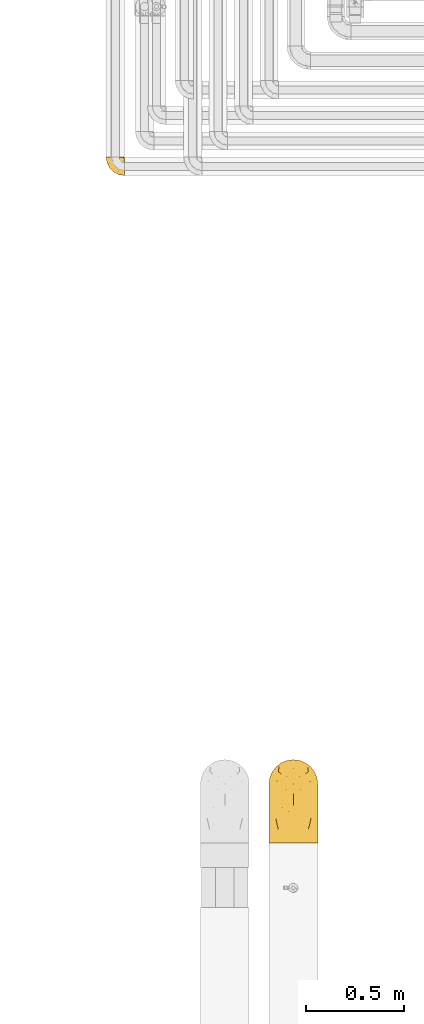
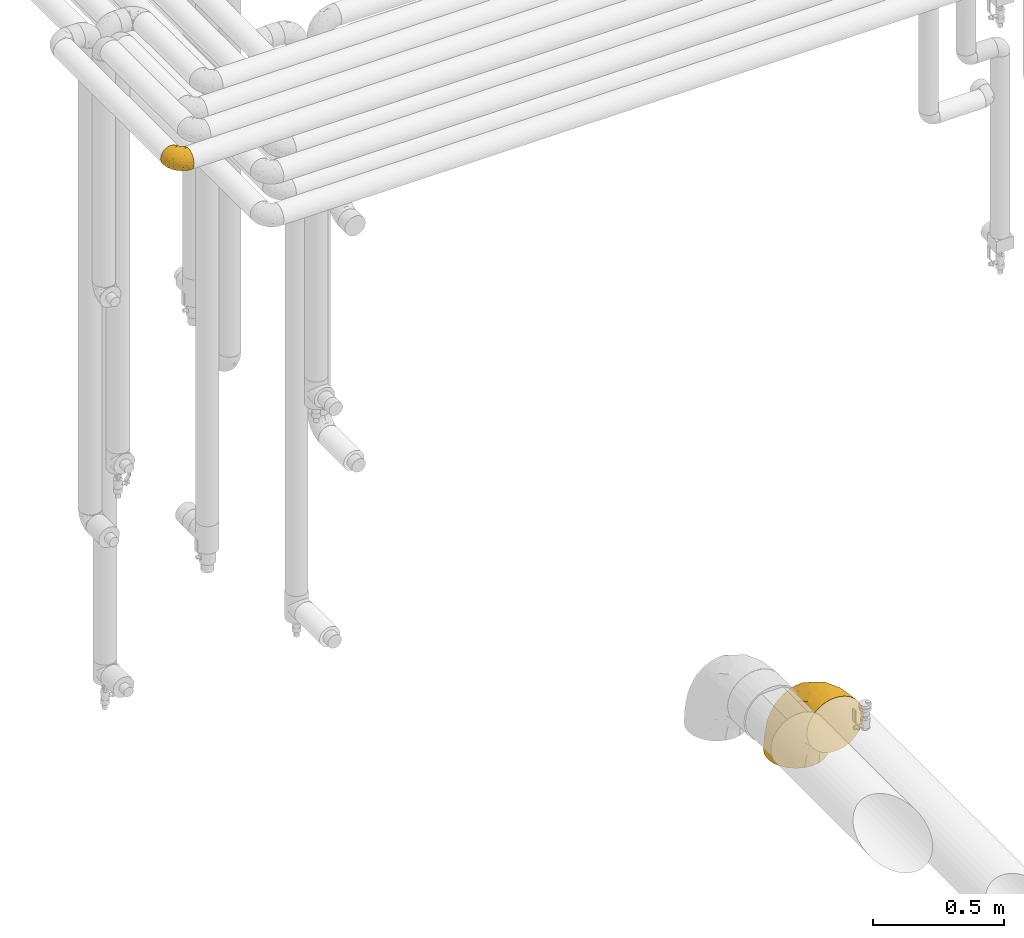
# One storey, part 142 of 827: 2 coverings.
"""IFC2X3 building model written with IfcOpenShell, lengths in millimetres."""

import ifcopenshell
import ifcopenshell.guid

model = None  # the IFC model being written
_history = None  # IfcOwnerHistory: only IFC2X3 demands one
_inside = {}  # id of a spatial element -> (the spatial element, [elements in it])
_under = {}  # id of a project, library or spatial element -> (it, [spatial elements below it])
_declared = {}  # id of a project -> (the project, [libraries it declares])
_typed = {}  # id of a type object -> (the type object, [elements of that type])
_made_of = {}  # id of a material, layer set ... -> (it, [elements and type objects made of it])


def new_model(schema):
    """Start an empty IFC model of exactly this schema.

    Asked for "IFC4X3", IfcOpenShell would pick the latest addendum, in which some entities
    have other attributes; the version numbers below select the first issue.
    IFC2X3 requires an IfcOwnerHistory on every rooted entity: one is made here for all.
    """
    global model, _history
    if schema == "IFC4X3":
        model = ifcopenshell.file(schema_version=(4, 3, 0, 0))
    else:
        model = ifcopenshell.file(schema=schema)
    _inside.clear()
    _under.clear()
    _declared.clear()
    _typed.clear()
    _made_of.clear()
    _history = None
    if model.schema == "IFC2X3":
        org = make("IfcOrganization", Name="unknown")
        user = make(
            "IfcPersonAndOrganization",
            ThePerson=make("IfcPerson", FamilyName="unknown"),
            TheOrganization=org,
        )
        app = make(
            "IfcApplication",
            ApplicationDeveloper=org,
            Version="unknown",
            ApplicationFullName="unknown",
            ApplicationIdentifier="unknown",
        )
        _history = make(
            "IfcOwnerHistory",
            OwningUser=user,
            OwningApplication=app,
            ChangeAction="ADDED",
            CreationDate=0,
        )
    return model


def make(cls, **values):
    """One entity of the class cls with the attributes given. An attribute that is None is left unset."""
    return model.create_entity(
        cls, **{name: value for name, value in values.items() if value is not None}
    )


def entity(cls, *values):
    """Any entity or typed value of the class cls, its attributes in the order of the schema. None: left unset."""
    e = model.create_entity(cls)
    for i, value in enumerate(values):
        if value is not None:
            e[i] = value
    return e


def rooted(cls, **values):
    """An entity with a GlobalId (a new one), such as an element, a storey or a relation."""
    return make(cls, GlobalId=ifcopenshell.guid.new(), OwnerHistory=_history, **values)


def si_unit(unit_type, name, prefix=None):
    """IfcSIUnit, for example si_unit("LENGTHUNIT", "METRE", prefix="MILLI")."""
    return make("IfcSIUnit", UnitType=unit_type, Prefix=prefix, Name=name)


def converted_unit(unit_type, name, factor, base, dimensions=None, offset=None):
    """IfcConversionBasedUnit, such as the inch: factor (a typed value) times the base unit."""
    return make(
        "IfcConversionBasedUnit"
        if offset is None
        else "IfcConversionBasedUnitWithOffset",
        ConversionOffset=offset,
        Dimensions=None
        if dimensions is None
        else entity("IfcDimensionalExponents", *dimensions),
        UnitType=unit_type,
        Name=name,
        ConversionFactor=make(
            "IfcMeasureWithUnit", ValueComponent=factor, UnitComponent=base
        ),
    )


def derived_unit(unit_type, elements):
    """IfcDerivedUnit: a product of units, each with its exponent."""
    return make(
        "IfcDerivedUnit",
        Elements=[
            make("IfcDerivedUnitElement", Unit=unit, Exponent=power)
            for unit, power in elements
        ],
        UnitType=unit_type,
    )


def assignment(units):
    """IfcUnitAssignment: the units of a project."""
    return None if units is None else make("IfcUnitAssignment", Units=units)


def point(xyz):
    """IfcCartesianPoint."""
    return None if xyz is None else make("IfcCartesianPoint", Coordinates=xyz)


def direction(xyz):
    """IfcDirection."""
    return None if xyz is None else make("IfcDirection", DirectionRatios=xyz)


def frame(location, z_axis=None, x_axis=None):
    """IfcAxis2Placement3D, a coordinate frame: its origin and axes. An axis left out is left unset."""
    return make(
        "IfcAxis2Placement3D",
        Location=point(location),
        Axis=direction(z_axis),
        RefDirection=direction(x_axis),
    )


def origin():
    """The frame at (0, 0, 0) with its axes left unset."""
    return frame((0.0, 0.0, 0.0))


def place(relative_to, where):
    """IfcLocalPlacement: puts the frame where relative to a parent placement (None: the world)."""
    return make(
        "IfcLocalPlacement", PlacementRelTo=relative_to, RelativePlacement=where
    )


def context(
    kind, dimensions, precision=None, world=None, true_north=None, identifier=None
):
    """IfcGeometricRepresentationContext, for example the 3D "Model" context."""
    return make(
        "IfcGeometricRepresentationContext",
        ContextIdentifier=identifier,
        ContextType=kind,
        CoordinateSpaceDimension=dimensions,
        Precision=precision,
        WorldCoordinateSystem=world,
        TrueNorth=true_north,
    )


def subcontext(parent, identifier, kind, view, scale=None):
    """IfcGeometricRepresentationSubContext, for example "Body" below "Model"."""
    return make(
        "IfcGeometricRepresentationSubContext",
        ContextIdentifier=identifier,
        ContextType=kind,
        ParentContext=parent,
        TargetScale=scale,
        TargetView=view,
    )


def project(units=None, contexts=None):
    """IfcProject with its units and contexts."""
    return rooted(
        "IfcProject",
        Name="project",
        RepresentationContexts=contexts,
        UnitsInContext=assignment(units),
    )


def spatial(cls, under=None, at=None, **own):
    """A site, building, storey or space (cls), placed at a placement, below another one or the project."""
    s = rooted(cls, ObjectPlacement=at, **own)
    if under is not None:
        _under.setdefault(under.id(), (under, []))[1].append(s)
    return s


def faces_of(points, faces, orient=None, outer=None):
    """IfcFace entities. A face is a list of loops; a loop is a list of indices into points, from 0.

    orient and outer hold one flag for each loop. By default every Orientation is true, the
    first loop of a face is its IfcFaceOuterBound and the others are IfcFaceBound.
    """
    made = []
    for i, loops in enumerate(faces):
        bounds = []
        for j, loop in enumerate(loops):
            is_outer = j == 0 if outer is None else outer[i][j]
            bounds.append(
                make(
                    "IfcFaceOuterBound" if is_outer else "IfcFaceBound",
                    Bound=make("IfcPolyLoop", Polygon=[points[k] for k in loop]),
                    Orientation=True if orient is None else orient[i][j],
                )
            )
        made.append(make("IfcFace", Bounds=bounds))
    return made


def faceted_brep(points, faces, orient=None, outer=None, voids=None):
    """IfcFacetedBrep: a solid bounded by flat faces; with voids (closed shells), ...WithVoids."""
    shared = [point(p) for p in points]
    hull = make("IfcClosedShell", CfsFaces=faces_of(shared, faces, orient, outer))
    if voids is None:
        return make("IfcFacetedBrep", Outer=hull)
    return make(
        "IfcFacetedBrepWithVoids",
        Outer=hull,
        Voids=[
            make(cls, CfsFaces=faces_of(shared, fs, o, b)) for cls, fs, o, b in voids
        ],
    )


def shape(context_of_items, identifier, shape_type, items):
    """IfcShapeRepresentation: the items that make up one representation, for example the "Body"."""
    return make(
        "IfcShapeRepresentation",
        ContextOfItems=context_of_items,
        RepresentationIdentifier=identifier,
        RepresentationType=shape_type,
        Items=items,
    )


def made_of(thing, what):
    """Note that an element or type object is made of a material, layer set ...; save() writes the relation."""
    if what is not None:
        _made_of.setdefault(what.id(), (what, []))[1].append(thing)
    return thing


def element(
    cls,
    number,
    at=None,
    inside=None,
    cuts=None,
    type_object=None,
    material=None,
    context=None,
    identifier="Body",
    shape_type=None,
    held_by="IfcProductDefinitionShape",
    body=None,
    shapes=None,
    **own,
):
    """One element of the class cls, such as IfcWall. Its Tag is "e" and its number.

    at: its placement. inside: the storey or other place that contains it. cuts: it is an
    opening in that element (IfcRelVoidsElement). A single representation is given by context,
    identifier, shape_type and body (its items); several are given by shapes. held_by: the class
    of the entity that holds the representations. save() writes the other relations.
    """
    e = rooted(cls, Tag="e%d" % number, ObjectPlacement=at, **own)
    if body is not None:
        shapes = [shape(context, identifier, shape_type, body)]
    if shapes is not None:
        e.Representation = make(held_by, Representations=shapes)
    if inside is not None:
        _inside.setdefault(inside.id(), (inside, []))[1].append(e)
    if cuts is not None:
        rooted(
            "IfcRelVoidsElement", RelatingBuildingElement=cuts, RelatedOpeningElement=e
        )
    if type_object is not None:
        _typed.setdefault(type_object.id(), (type_object, []))[1].append(e)
    return made_of(e, material)


def aggregate(whole, parts):
    """IfcRelAggregates: a whole, such as a stair, and the parts it consists of."""
    return rooted("IfcRelAggregates", RelatingObject=whole, RelatedObjects=parts)


def save(model, path):
    """Write the relations noted so far, then the file.

    IfcRelAggregates (storeys below a building ...), IfcRelContainedInSpatialStructure (elements
    in a storey), IfcRelDefinesByType, IfcRelAssociatesMaterial and IfcRelDeclares: one each for
    every whole, place, type object, material and project.
    """
    for whole, parts in _under.values():
        aggregate(whole, parts)
    for where, things in _inside.values():
        rooted(
            "IfcRelContainedInSpatialStructure",
            RelatedElements=things,
            RelatingStructure=where,
        )
    for kind, things in _typed.values():
        rooted("IfcRelDefinesByType", RelatedObjects=things, RelatingType=kind)
    for what, things in _made_of.values():
        rooted("IfcRelAssociatesMaterial", RelatedObjects=things, RelatingMaterial=what)
    for by, libraries in _declared.values():
        rooted("IfcRelDeclares", RelatingContext=by, RelatedDefinitions=libraries)
    model.write(path)


model = new_model("IFC2X3")

# Units and contexts
model_context = context("Model", 3, precision=0.01, world=origin(), true_north=direction((6.12303176911189e-17, 1.0)))
body_context = subcontext(model_context, "Body", "Model", "MODEL_VIEW")
ifc_project = project(units=[si_unit("LENGTHUNIT", "METRE", prefix="MILLI"), si_unit("AREAUNIT", "SQUARE_METRE"), si_unit("VOLUMEUNIT", "CUBIC_METRE"), converted_unit("PLANEANGLEUNIT", "DEGREE", entity("IfcRatioMeasure", 0.0174532925199433), si_unit("PLANEANGLEUNIT", "RADIAN"), dimensions=[0, 0, 0, 0, 0, 0, 0]), si_unit("MASSUNIT", "GRAM", prefix="KILO"), derived_unit("MASSDENSITYUNIT", [(si_unit("MASSUNIT", "GRAM", prefix="KILO"), 1), (si_unit("LENGTHUNIT", "METRE"), -3)]), derived_unit("MOMENTOFINERTIAUNIT", [(si_unit("LENGTHUNIT", "METRE"), 4)]), si_unit("TIMEUNIT", "SECOND"), si_unit("FREQUENCYUNIT", "HERTZ"), si_unit("THERMODYNAMICTEMPERATUREUNIT", "DEGREE_CELSIUS"), derived_unit("THERMALTRANSMITTANCEUNIT", [(si_unit("MASSUNIT", "GRAM", prefix="KILO"), 1), (si_unit("THERMODYNAMICTEMPERATUREUNIT", "KELVIN"), -1), (si_unit("TIMEUNIT", "SECOND"), -3)]), derived_unit("VOLUMETRICFLOWRATEUNIT", [(si_unit("LENGTHUNIT", "METRE"), 3), (si_unit("TIMEUNIT", "SECOND"), -1)]), derived_unit("MASSFLOWRATEUNIT", [(si_unit("MASSUNIT", "GRAM", prefix="KILO"), 1), (si_unit("TIMEUNIT", "SECOND"), -1)]), derived_unit("ROTATIONALFREQUENCYUNIT", [(si_unit("TIMEUNIT", "SECOND"), -1)]), si_unit("ELECTRICCURRENTUNIT", "AMPERE"), si_unit("ELECTRICVOLTAGEUNIT", "VOLT"), si_unit("POWERUNIT", "WATT"), si_unit("FORCEUNIT", "NEWTON", prefix="KILO"), si_unit("ILLUMINANCEUNIT", "LUX"), si_unit("LUMINOUSFLUXUNIT", "LUMEN"), si_unit("LUMINOUSINTENSITYUNIT", "CANDELA"), derived_unit("USERDEFINED", [(si_unit("MASSUNIT", "GRAM", prefix="KILO"), -1), (si_unit("LENGTHUNIT", "METRE"), -2), (si_unit("TIMEUNIT", "SECOND"), 3), (si_unit("LUMINOUSFLUXUNIT", "LUMEN"), 1)]), derived_unit("LINEARVELOCITYUNIT", [(si_unit("LENGTHUNIT", "METRE"), 1), (si_unit("TIMEUNIT", "SECOND"), -1)]), si_unit("PRESSUREUNIT", "PASCAL"), derived_unit("USERDEFINED", [(si_unit("LENGTHUNIT", "METRE"), -2), (si_unit("MASSUNIT", "GRAM", prefix="KILO"), 1), (si_unit("TIMEUNIT", "SECOND"), -2)]), derived_unit("LINEARFORCEUNIT", [(si_unit("MASSUNIT", "GRAM", prefix="KILO"), 1), (si_unit("LENGTHUNIT", "METRE"), 1), (si_unit("TIMEUNIT", "SECOND"), -2), (si_unit("LENGTHUNIT", "METRE"), -1)]), derived_unit("PLANARFORCEUNIT", [(si_unit("MASSUNIT", "GRAM", prefix="KILO"), 1), (si_unit("LENGTHUNIT", "METRE"), 1), (si_unit("TIMEUNIT", "SECOND"), -2), (si_unit("LENGTHUNIT", "METRE"), -2)])], contexts=[model_context])

# Site, building, storey
site_placement = place(None, origin())
site = spatial("IfcSite", under=ifc_project, at=site_placement, CompositionType="ELEMENT")
building_placement = place(site_placement, origin())
building = spatial("IfcBuilding", under=site, at=building_placement, CompositionType="ELEMENT")
storey_placement = place(building_placement, frame((0.0, 0.0, 28200.0)))
storey = spatial("IfcBuildingStorey", under=building, at=storey_placement, Name="08", CompositionType="ELEMENT", Elevation=28200.0)

# Coverings
covering_1_placement = place(storey_placement, frame((30473.73, 14052.21, 3352.2)))
element("IfcCovering", 1, at=covering_1_placement, inside=storey, Name=":ADSK_", ObjectType=":ADSK_", PredefinedType="INSULATION", context=body_context, shape_type="Brep", body=[
    faceted_brep([(95.8, 18.98, 83.91), (95.8, 11.67, 76.59), (95.8, 6.17, 67.83), (95.8, 2.75, 58.07), (95.8, 1.6, 47.8), (95.8, 2.75, 37.51), (95.8, 6.17, 27.74), (95.8, 11.68, 18.98), (95.8, 19.0, 11.67), (95.8, 27.76, 6.17), (95.8, 37.52, 2.75), (95.8, 47.8, 1.6), (95.8, 51.94, 2.06), (95.8, 55.01, 2.41), (95.8, 58.08, 2.75), (95.8, 62.96, 4.46), (95.8, 67.85, 6.17), (95.8, 72.23, 8.93), (95.8, 76.61, 11.68), (95.8, 80.26, 15.34), (95.8, 83.92, 19.0), (95.8, 89.42, 27.76), (95.8, 91.13, 32.64), (95.8, 92.84, 37.52), (95.8, 94.0, 47.8), (95.8, 92.84, 58.08), (95.8, 91.13, 62.96), (95.8, 89.42, 67.85), (95.8, 83.91, 76.61), (95.8, 80.25, 80.26), (95.8, 76.59, 83.92), (95.8, 72.21, 86.67), (95.8, 67.83, 89.42), (95.8, 62.95, 91.13), (95.8, 58.07, 92.84), (95.8, 55.0, 93.18), (95.8, 51.94, 93.53), (95.8, 47.8, 94.0), (95.8, 37.51, 92.84), (95.8, 27.74, 89.42), (94.0, 95.8, 47.8), (92.42, 95.8, 35.84), (87.81, 95.8, 24.7), (84.13, 95.8, 19.91), (80.46, 95.8, 15.13), (75.68, 95.8, 11.46), (70.9, 95.8, 7.78), (65.32, 95.8, 5.48), (59.75, 95.8, 3.17), (56.14, 95.8, 2.69), (54.06, 95.8, 2.42), (51.97, 95.8, 2.14), (47.8, 95.8, 1.6), (35.84, 95.8, 3.17), (24.7, 95.8, 7.78), (15.13, 95.8, 15.13), (7.78, 95.8, 24.7), (3.17, 95.8, 35.84), (1.6, 95.8, 47.8), (3.17, 95.8, 59.75), (7.78, 95.8, 70.9), (15.13, 95.8, 80.46), (24.7, 95.8, 87.81), (35.84, 95.8, 92.42), (47.8, 95.8, 94.0), (51.97, 95.8, 93.45), (56.14, 95.8, 92.9), (59.75, 95.8, 92.42), (65.32, 95.8, 90.11), (70.9, 95.8, 87.81), (75.68, 95.8, 84.13), (80.46, 95.8, 80.46), (84.13, 95.8, 75.68), (87.81, 95.8, 70.9), (92.42, 95.8, 59.75), (15.84, 60.58, 71.98), (6.99, 74.11, 63.6), (14.39, 51.59, 59.72), (6.21, 66.69, 47.8), (4.26, 76.19, 55.16), (3.39, 84.43, 47.8), (31.2, 31.2, 63.76), (26.47, 42.88, 72.22), (11.44, 79.41, 74.18), (47.66, 60.7, 92.52), (61.85, 61.85, 94.0), (59.25, 65.75, 94.0), (56.65, 69.64, 94.0), (54.05, 73.53, 94.0), (51.45, 77.43, 94.0), (19.8, 74.59, 82.14), (26.22, 54.72, 80.34), (31.58, 64.18, 87.52), (38.36, 37.94, 79.59), (51.54, 25.89, 78.25), (51.6, 34.73, 85.01), (55.97, 42.89, 90.25), (62.88, 49.83, 93.2), (41.35, 48.58, 87.23), (82.24, 22.41, 85.55), (40.88, 78.69, 93.0), (29.0, 81.64, 89.31), (74.06, 6.22, 61.31), (54.53, 12.11, 56.86), (57.98, 14.81, 68.34), (43.81, 21.61, 65.71), (38.22, 22.41, 56.99), (38.33, 30.12, 72.15), (74.76, 10.01, 70.34), (76.85, 15.36, 78.36), (84.43, 3.39, 47.8), (40.43, 19.59, 47.8), (30.01, 30.01, 47.8), (78.67, 41.19, 93.06), (92.06, 48.54, 94.0), (88.32, 49.28, 94.0), (85.6, 49.82, 94.0), (82.88, 50.37, 94.0), (80.15, 50.91, 94.0), (77.43, 51.45, 94.0), (76.36, 31.61, 89.88), (50.91, 80.15, 94.0), (50.37, 82.88, 94.0), (49.82, 85.6, 94.0), (49.28, 88.32, 94.0), (48.91, 90.19, 94.0), (48.54, 92.06, 94.0), (66.69, 6.21, 47.8), (73.53, 54.05, 94.0), (69.64, 56.65, 94.0), (65.75, 59.25, 94.0), (66.13, 24.66, 83.7), (19.59, 40.43, 47.8), (24.64, 35.17, 55.9), (53.56, 12.9, 47.8), (12.9, 53.56, 47.8), (82.81, 85.34, 81.75), (81.22, 78.44, 86.43), (86.57, 84.37, 79.8), (92.75, 89.05, 69.84), (72.26, 86.31, 88.08), (64.73, 83.73, 91.6), (62.45, 77.31, 92.93), (60.63, 87.78, 92.43), (56.91, 87.91, 93.24), (58.14, 81.29, 93.36), (93.7, 93.97, 57.25), (83.4, 70.76, 89.41), (75.54, 63.67, 92.89), (79.46, 62.62, 92.66), (82.28, 90.64, 79.58), (76.25, 84.08, 86.51), (90.18, 77.45, 83.91), (87.92, 70.34, 88.76), (65.12, 88.72, 90.94), (71.71, 71.28, 91.94), (75.21, 68.09, 91.98), (78.6, 91.07, 82.79), (87.27, 57.47, 93.16), (86.94, 91.35, 73.94), (86.1, 62.99, 91.89), (94.52, 94.52, 47.8), (89.68, 82.76, 79.5), (66.23, 76.47, 92.22), (84.69, 76.28, 86.29), (91.08, 69.96, 88.56), (71.77, 89.86, 87.72), (76.21, 78.94, 88.33), (68.59, 73.51, 92.18), (89.94, 89.62, 71.78), (76.25, 84.09, 9.09), (72.26, 86.3, 7.51), (78.6, 91.06, 12.8), (49.28, 88.32, 1.6), (48.54, 92.06, 1.6), (50.37, 82.88, 1.6), (49.82, 85.6, 1.6), (93.7, 93.97, 38.35), (89.95, 89.63, 23.84), (82.88, 50.37, 1.6), (85.6, 49.82, 1.6), (92.06, 48.54, 1.6), (88.32, 49.28, 1.6), (89.68, 82.77, 16.1), (87.92, 70.36, 6.84), (62.45, 77.31, 2.66), (66.24, 76.47, 3.37), (56.65, 69.64, 1.6), (59.25, 65.75, 1.6), (60.63, 87.78, 3.16), (56.91, 87.91, 2.35), (92.76, 89.06, 25.77), (82.28, 90.65, 16.02), (82.81, 85.35, 13.85), (54.05, 73.53, 1.6), (51.45, 77.43, 1.6), (58.14, 81.29, 2.23), (90.18, 77.46, 11.69), (84.7, 76.29, 9.31), (87.25, 57.47, 2.43), (75.58, 63.71, 2.71), (75.2, 68.11, 3.61), (83.39, 70.77, 6.18), (71.7, 71.31, 3.66), (81.22, 78.46, 9.17), (90.73, 69.52, 6.77), (79.47, 62.64, 2.93), (86.94, 91.35, 21.66), (65.75, 59.25, 1.6), (86.75, 84.6, 16.09), (86.08, 62.98, 3.7), (77.43, 51.45, 1.6), (73.53, 54.05, 1.6), (69.64, 56.65, 1.6), (64.73, 83.73, 3.99), (50.91, 80.15, 1.6), (65.12, 88.72, 4.65), (61.85, 61.85, 1.6), (68.62, 73.56, 3.43), (76.22, 78.96, 7.27), (74.03, 91.36, 9.46), (80.15, 50.91, 1.6), (49.81, 62.87, 2.4), (4.26, 76.19, 40.43), (19.95, 73.57, 13.57), (30.61, 56.07, 11.3), (25.71, 49.77, 18.65), (22.43, 44.73, 27.26), (15.85, 60.58, 23.61), (60.69, 47.64, 3.07), (40.49, 78.32, 2.69), (14.39, 51.59, 35.87), (6.99, 74.11, 31.99), (29.56, 76.04, 6.71), (11.45, 79.41, 21.41), (57.98, 14.82, 27.24), (74.06, 6.22, 34.26), (54.52, 12.12, 38.73), (43.47, 23.51, 26.97), (31.2, 31.2, 31.83), (33.27, 34.96, 23.4), (64.26, 33.86, 6.91), (74.29, 38.94, 3.4), (80.41, 30.23, 5.84), (24.64, 35.17, 39.69), (73.62, 15.85, 17.6), (78.98, 22.59, 10.38), (53.69, 21.56, 20.6), (42.86, 55.94, 5.36), (41.67, 20.67, 35.73), (79.66, 9.19, 24.84), (58.41, 25.79, 13.87), (47.11, 41.16, 9.06), (38.37, 37.95, 15.99)], [[[0, 1, 2, 3, 4, 5, 6, 7, 8, 9, 10, 11, 12, 13, 14, 15, 16, 17, 18, 19, 20, 21, 22, 23, 24, 25, 26, 27, 28, 29, 30, 31, 32, 33, 34, 35, 36, 37, 38, 39]], [[40, 41, 42, 43, 44, 45, 46, 47, 48, 49, 50, 51, 52, 53, 54, 55, 56, 57, 58, 59, 60, 61, 62, 63, 64, 65, 66, 67, 68, 69, 70, 71, 72, 73, 74]], [[75, 76, 77]], [[78, 79, 80]], [[77, 81, 82]], [[76, 75, 83]], [[84, 85, 86, 87, 88, 89]], [[90, 91, 92]], [[76, 60, 59]], [[93, 94, 95]], [[90, 62, 61]], [[83, 61, 60]], [[96, 97, 84]], [[98, 93, 95]], [[0, 39, 99]], [[100, 84, 89]], [[62, 101, 63]], [[2, 102, 3]], [[92, 84, 100]], [[103, 102, 104]], [[103, 105, 106]], [[93, 107, 94]], [[1, 108, 2]], [[92, 101, 90]], [[108, 1, 109]], [[102, 110, 3]], [[93, 82, 107]], [[102, 108, 104]], [[111, 106, 112]], [[109, 0, 99]], [[113, 37, 114, 115, 116, 117, 118, 119]], [[120, 38, 113]], [[100, 89, 121, 122, 123, 124, 125, 126, 64]], [[127, 102, 103]], [[97, 119, 128, 129, 130, 85]], [[99, 120, 131]], [[132, 133, 77]], [[59, 80, 79]], [[1, 0, 109]], [[98, 84, 92]], [[94, 109, 131]], [[120, 39, 38]], [[93, 91, 82]], [[104, 94, 105]], [[97, 113, 119]], [[95, 120, 96]], [[83, 90, 61]], [[91, 93, 98]], [[64, 63, 100]], [[100, 63, 101]], [[77, 76, 79]], [[133, 106, 81]], [[84, 97, 85]], [[113, 96, 120]], [[113, 97, 96]], [[37, 113, 38]], [[110, 102, 127]], [[110, 4, 3]], [[103, 111, 134, 127]], [[90, 75, 91]], [[82, 81, 107]], [[91, 75, 82]], [[77, 82, 75]], [[76, 83, 60]], [[90, 83, 75]], [[105, 107, 81]], [[94, 131, 95]], [[105, 94, 107]], [[109, 94, 104]], [[120, 95, 131]], [[98, 95, 96]], [[84, 98, 96]], [[98, 92, 91]], [[106, 105, 81]], [[103, 104, 105]], [[112, 106, 133]], [[103, 106, 111]], [[112, 133, 132]], [[81, 77, 133]], [[77, 78, 135, 132]], [[120, 99, 39]], [[109, 99, 131]], [[59, 58, 80]], [[59, 79, 76]], [[90, 101, 62]], [[100, 101, 92]], [[2, 108, 102]], [[109, 104, 108]], [[78, 77, 79]], [[136, 137, 138]], [[27, 26, 25, 139]], [[140, 141, 142]], [[143, 144, 121]], [[145, 89, 88]], [[146, 139, 25]], [[147, 148, 149]], [[136, 150, 151]], [[146, 40, 74]], [[24, 146, 25]], [[152, 147, 153]], [[33, 116, 34]], [[73, 72, 150]], [[114, 37, 36, 35, 34, 116, 115]], [[145, 154, 143]], [[155, 85, 130]], [[156, 148, 147]], [[150, 157, 151]], [[117, 33, 158]], [[29, 152, 153]], [[159, 74, 73]], [[160, 128, 119]], [[66, 65, 64, 126, 125, 124, 123, 122, 67]], [[161, 146, 24]], [[27, 162, 28]], [[148, 129, 149]], [[68, 143, 69]], [[129, 128, 149]], [[163, 87, 86]], [[130, 129, 148]], [[122, 144, 67]], [[152, 164, 147]], [[160, 119, 158]], [[165, 30, 153]], [[149, 153, 147]], [[128, 160, 149]], [[30, 165, 31]], [[144, 143, 68]], [[89, 145, 143]], [[87, 163, 142]], [[166, 154, 141]], [[88, 87, 142]], [[160, 153, 149]], [[153, 30, 29]], [[29, 28, 152]], [[28, 162, 152]], [[164, 152, 162]], [[162, 137, 164]], [[156, 147, 164]], [[155, 130, 156]], [[164, 137, 156]], [[156, 137, 155]], [[167, 137, 136]], [[168, 85, 155]], [[151, 168, 167]], [[167, 168, 155]], [[163, 151, 140]], [[71, 157, 72]], [[151, 167, 136]], [[88, 141, 145]], [[143, 154, 69]], [[145, 141, 154]], [[70, 166, 71]], [[141, 140, 166]], [[70, 69, 154]], [[140, 157, 71]], [[159, 73, 150]], [[138, 137, 162]], [[159, 136, 169]], [[136, 159, 150]], [[74, 159, 169]], [[151, 157, 140]], [[150, 72, 157]], [[168, 151, 163]], [[137, 167, 155]], [[163, 86, 168]], [[85, 168, 86]], [[116, 33, 117]], [[130, 148, 156]], [[67, 144, 68]], [[121, 89, 143]], [[144, 122, 121]], [[40, 146, 161]], [[169, 146, 74]], [[158, 33, 32]], [[160, 158, 32]], [[158, 119, 118, 117]], [[139, 146, 169]], [[138, 139, 169]], [[162, 27, 139]], [[160, 32, 31]], [[140, 142, 163]], [[88, 142, 141]], [[71, 166, 140]], [[154, 166, 70]], [[139, 138, 162]], [[169, 136, 138]], [[153, 160, 165]], [[160, 31, 165]], [[170, 171, 172]], [[173, 174, 52, 51, 50, 49, 48, 175, 176]], [[177, 178, 41]], [[179, 15, 180]], [[12, 11, 181, 182, 180, 14, 13]], [[183, 21, 20]], [[19, 18, 184]], [[185, 186, 187]], [[186, 188, 187]], [[43, 172, 44]], [[189, 190, 47]], [[23, 22, 21, 191]], [[170, 192, 193]], [[40, 161, 177]], [[194, 195, 196]], [[24, 23, 177]], [[197, 198, 183]], [[199, 15, 179]], [[47, 46, 189]], [[200, 201, 202]], [[201, 203, 204]], [[205, 206, 184]], [[207, 41, 178]], [[16, 15, 199]], [[14, 180, 15]], [[202, 201, 198]], [[208, 201, 200]], [[161, 24, 177]], [[48, 47, 190]], [[196, 195, 189]], [[197, 184, 202]], [[204, 193, 209]], [[210, 211, 212]], [[206, 212, 213]], [[205, 17, 210]], [[184, 206, 202]], [[210, 212, 206]], [[185, 194, 214]], [[189, 215, 190]], [[216, 45, 214]], [[186, 171, 170]], [[189, 216, 196]], [[197, 20, 19]], [[194, 185, 187]], [[197, 183, 20]], [[184, 197, 19]], [[197, 202, 198]], [[206, 200, 202]], [[204, 183, 198]], [[201, 208, 203]], [[203, 208, 217]], [[204, 198, 201]], [[217, 188, 218]], [[193, 219, 170]], [[171, 186, 185]], [[170, 218, 186]], [[170, 219, 218]], [[42, 207, 192]], [[171, 220, 172]], [[216, 189, 46]], [[214, 194, 196]], [[44, 220, 45]], [[214, 196, 216]], [[216, 46, 45]], [[214, 45, 220]], [[192, 43, 42]], [[204, 203, 219]], [[207, 193, 192]], [[209, 193, 178]], [[41, 207, 42]], [[193, 207, 178]], [[43, 192, 172]], [[170, 172, 192]], [[204, 219, 193]], [[219, 203, 218]], [[217, 218, 203]], [[188, 186, 218]], [[206, 213, 200]], [[208, 200, 213]], [[199, 210, 16]], [[215, 189, 195]], [[215, 175, 190]], [[175, 48, 190]], [[199, 179, 221, 211]], [[210, 199, 211]], [[23, 191, 177]], [[40, 177, 41]], [[178, 177, 191]], [[21, 183, 191]], [[209, 191, 183]], [[205, 18, 17]], [[17, 16, 210]], [[171, 185, 214]], [[172, 220, 44]], [[214, 220, 171]], [[191, 209, 178]], [[204, 209, 183]], [[206, 205, 210]], [[18, 205, 184]], [[222, 195, 194, 187, 188, 217]], [[57, 223, 80]], [[224, 225, 226]], [[226, 227, 228]], [[229, 217, 208, 213, 212, 211]], [[230, 52, 174, 173, 176, 175, 215, 195]], [[231, 232, 228]], [[231, 78, 223]], [[223, 57, 232]], [[224, 233, 225]], [[233, 54, 53]], [[234, 232, 56]], [[56, 55, 234]], [[234, 224, 228]], [[235, 236, 237]], [[224, 55, 54]], [[238, 239, 240]], [[52, 230, 53]], [[241, 242, 243]], [[227, 244, 231]], [[11, 10, 242]], [[236, 6, 5]], [[7, 245, 8]], [[8, 246, 9]], [[238, 247, 235]], [[222, 229, 248]], [[242, 211, 221, 179, 180, 182, 181, 11]], [[233, 53, 230]], [[111, 112, 249]], [[250, 6, 236]], [[246, 251, 241]], [[6, 250, 7]], [[127, 236, 110]], [[248, 229, 252]], [[246, 8, 245]], [[235, 245, 250]], [[236, 5, 110]], [[235, 249, 238]], [[237, 236, 127]], [[243, 9, 246]], [[252, 229, 241]], [[56, 232, 57]], [[222, 230, 195]], [[225, 248, 252]], [[248, 233, 230]], [[54, 233, 224]], [[231, 228, 227]], [[244, 132, 231]], [[248, 225, 233]], [[226, 225, 253]], [[235, 250, 236]], [[245, 7, 250]], [[251, 246, 245]], [[243, 246, 241]], [[247, 245, 235]], [[252, 251, 253]], [[229, 222, 217]], [[230, 222, 248]], [[5, 4, 110]], [[237, 127, 134, 111]], [[238, 249, 239]], [[224, 234, 55]], [[232, 234, 228]], [[242, 241, 229]], [[10, 9, 243]], [[211, 242, 229]], [[10, 243, 242]], [[80, 223, 78]], [[80, 58, 57]], [[231, 223, 232]], [[227, 240, 239]], [[224, 226, 228]], [[240, 226, 253]], [[227, 239, 244]], [[226, 240, 227]], [[251, 247, 253]], [[240, 253, 247]], [[249, 235, 237]], [[237, 111, 249]], [[112, 132, 244]], [[112, 244, 249]], [[78, 231, 132, 135]], [[249, 244, 239]], [[247, 238, 240]], [[245, 247, 251]], [[251, 252, 241]], [[225, 252, 253]]]),
])
covering_2_placement = place(storey_placement, frame((31303.9, 10648.4, 2248.4)))
element("IfcCovering", 2, at=covering_2_placement, inside=storey, Name=":ADSK_", ObjectType=":ADSK_", PredefinedType="INSULATION", context=body_context, shape_type="Brep", body=[
    faceted_brep([(249.06, 1.6, 282.13), (250.6, 1.6, 301.6), (249.06, 1.6, 321.07), (244.5, 1.6, 340.07), (237.02, 1.6, 358.12), (226.82, 1.6, 374.78), (214.13, 1.6, 389.63), (199.27, 1.6, 402.32), (182.61, 1.6, 412.53), (164.56, 1.6, 420.0), (145.56, 1.6, 424.56), (126.1, 1.6, 426.1), (106.62, 1.6, 424.56), (87.62, 1.6, 420.0), (69.57, 1.6, 412.52), (52.91, 1.6, 402.32), (38.06, 1.6, 389.63), (25.37, 1.6, 374.77), (15.16, 1.6, 358.11), (7.69, 1.6, 340.06), (3.13, 1.6, 321.06), (1.6, 1.6, 301.6), (3.13, 1.6, 282.12), (7.69, 1.6, 263.12), (15.17, 1.6, 245.07), (25.37, 1.6, 228.41), (38.06, 1.6, 213.56), (52.92, 1.6, 200.87), (69.58, 1.6, 190.66), (87.63, 1.6, 183.19), (106.63, 1.6, 178.63), (126.1, 1.6, 177.1), (145.57, 1.6, 178.63), (164.57, 1.6, 183.19), (182.62, 1.6, 190.67), (199.28, 1.6, 200.87), (214.13, 1.6, 213.56), (226.82, 1.6, 228.42), (237.03, 1.6, 245.08), (244.5, 1.6, 263.13), (38.06, 213.56, 1.6), (18.28, 239.35, 1.6), (5.84, 269.37, 1.6), (1.6, 301.6, 1.6), (5.84, 333.82, 1.6), (18.28, 363.85, 1.6), (38.06, 389.63, 1.6), (63.85, 409.42, 1.6), (93.87, 421.85, 1.6), (126.1, 426.1, 1.6), (158.32, 421.85, 1.6), (188.35, 409.42, 1.6), (214.13, 389.63, 1.6), (233.92, 363.85, 1.6), (246.35, 333.82, 1.6), (250.6, 301.6, 1.6), (246.35, 269.37, 1.6), (233.92, 239.35, 1.6), (214.13, 213.56, 1.6), (188.35, 193.78, 1.6), (158.32, 181.34, 1.6), (126.1, 177.1, 1.6), (93.87, 181.34, 1.6), (63.85, 193.78, 1.6), (126.1, 420.87, 68.0), (159.79, 390.52, 159.76), (171.65, 410.45, 77.64), (148.37, 413.12, 97.22), (170.98, 100.5, 405.8), (151.53, 161.37, 392.04), (148.43, 90.99, 414.51), (126.1, 405.32, 132.77), (126.1, 379.83, 194.31), (126.1, 132.77, 405.32), (126.1, 194.31, 379.83), (163.78, 273.0, 320.36), (158.07, 341.88, 248.34), (126.1, 301.76, 301.76), (216.14, 126.78, 366.71), (230.6, 175.34, 325.62), (215.18, 197.92, 335.07), (237.51, 344.83, 94.41), (220.0, 359.37, 134.75), (240.62, 301.84, 179.18), (126.1, 345.02, 251.11), (186.25, 352.47, 211.76), (126.1, 251.11, 345.02), (238.35, 97.73, 342.12), (222.84, 375.5, 59.52), (247.51, 252.9, 211.65), (242.96, 174.94, 297.5), (248.72, 168.15, 276.6), (247.51, 310.43, 110.66), (198.61, 391.69, 95.34), (238.33, 249.69, 253.95), (250.6, 278.76, 116.4), (250.6, 251.04, 168.27), (185.0, 182.02, 369.41), (250.6, 213.73, 213.73), (196.36, 265.35, 306.0), (204.33, 75.24, 391.55), (126.1, 68.0, 420.87), (250.6, 60.12, 295.83), (248.1, 108.56, 308.28), (250.6, 168.27, 251.04), (250.6, 116.4, 278.76), (250.6, 295.83, 60.12), (210.72, 315.85, 234.78), (228.5, 300.02, 221.69), (202.78, 365.06, 163.96), (223.0, 247.44, 288.95), (161.59, 144.62, 111.98), (126.1, 153.58, 89.35), (154.22, 165.92, 71.87), (245.5, 258.71, 64.74), (229.55, 87.33, 215.82), (225.61, 47.08, 222.14), (214.98, 74.58, 201.51), (208.87, 166.65, 126.52), (222.51, 142.22, 172.37), (202.61, 121.62, 163.8), (240.31, 92.94, 234.78), (182.2, 91.52, 167.67), (158.82, 53.04, 173.96), (156.41, 111.31, 143.34), (247.49, 245.91, 121.95), (244.95, 55.96, 258.85), (229.45, 183.54, 143.25), (246.68, 211.66, 169.65), (229.97, 227.63, 51.0), (126.1, 171.12, 47.02), (175.48, 181.99, 45.74), (182.39, 166.86, 93.2), (126.1, 47.02, 171.12), (126.1, 89.35, 153.58), (183.62, 135.0, 136.31), (126.1, 125.69, 125.69), (244.1, 163.44, 205.48), (248.44, 125.41, 249.33), (209.02, 198.38, 66.24), (235.25, 129.94, 204.54), (235.58, 165.64, 177.77), (183.86, 48.55, 185.41), (235.31, 217.22, 107.5), (5.51, 211.66, 169.66), (22.75, 183.55, 143.22), (16.61, 165.65, 177.76), (90.61, 144.62, 111.98), (69.8, 166.86, 93.2), (97.97, 165.92, 71.87), (26.59, 47.08, 222.13), (1.6, 278.76, 116.4), (4.7, 245.91, 121.95), (1.6, 251.04, 168.27), (95.79, 111.31, 143.34), (22.64, 87.33, 215.81), (11.89, 92.95, 234.77), (68.58, 134.99, 136.3), (93.38, 53.04, 173.96), (6.69, 258.71, 64.74), (1.6, 295.83, 60.12), (1.6, 213.73, 213.73), (8.09, 163.45, 205.49), (16.94, 129.95, 204.53), (43.34, 166.63, 126.53), (22.22, 227.63, 51.0), (43.17, 198.38, 66.24), (70.0, 91.52, 167.66), (1.6, 116.4, 278.76), (7.24, 55.97, 258.84), (1.6, 60.12, 295.83), (76.71, 181.99, 45.74), (68.34, 48.55, 185.4), (16.88, 217.22, 107.5), (37.22, 74.58, 201.5), (29.69, 142.23, 172.36), (49.59, 121.62, 163.8), (3.75, 125.4, 249.33), (1.6, 168.27, 251.04), (4.68, 310.43, 110.66), (29.2, 247.44, 288.95), (21.6, 175.33, 325.63), (37.02, 197.92, 335.08), (4.68, 252.9, 211.65), (67.18, 182.0, 369.41), (81.2, 100.49, 405.8), (100.65, 161.37, 392.04), (13.83, 97.72, 342.12), (14.68, 344.83, 94.41), (29.35, 375.5, 59.51), (53.58, 391.69, 95.34), (9.24, 174.94, 297.5), (3.47, 168.15, 276.6), (11.57, 301.84, 179.18), (92.4, 390.52, 159.76), (80.54, 410.45, 77.64), (47.86, 75.24, 391.55), (32.19, 359.37, 134.74), (88.4, 273.0, 320.36), (55.83, 265.34, 306.02), (103.83, 413.12, 97.22), (94.12, 341.88, 248.34), (65.94, 352.47, 211.76), (41.48, 315.85, 234.79), (103.76, 90.98, 414.51), (4.09, 108.56, 308.29), (13.86, 249.69, 253.95), (23.69, 300.02, 221.69), (36.04, 126.78, 366.7), (49.41, 365.06, 163.97)], [[[0, 1, 2, 3, 4, 5, 6, 7, 8, 9, 10, 11, 12, 13, 14, 15, 16, 17, 18, 19, 20, 21, 22, 23, 24, 25, 26, 27, 28, 29, 30, 31, 32, 33, 34, 35, 36, 37, 38, 39]], [[40, 41, 42, 43, 44, 45, 46, 47, 48, 49, 50, 51, 52, 53, 54, 55, 56, 57, 58, 59, 60, 61, 62, 63]], [[49, 64, 50]], [[65, 66, 67]], [[68, 69, 70]], [[65, 71, 72]], [[71, 65, 67]], [[73, 69, 74]], [[75, 76, 77]], [[78, 79, 80]], [[65, 72, 76]], [[51, 50, 66]], [[81, 82, 83]], [[84, 76, 72]], [[76, 85, 65]], [[74, 69, 86]], [[5, 87, 78]], [[52, 88, 53]], [[89, 90, 91]], [[55, 54, 92]], [[82, 88, 93]], [[94, 89, 83]], [[87, 90, 79]], [[95, 89, 96]], [[5, 4, 87]], [[83, 89, 92]], [[90, 89, 94]], [[78, 80, 97]], [[65, 85, 93]], [[95, 92, 89]], [[96, 89, 98]], [[99, 75, 97]], [[3, 87, 4]], [[90, 94, 79]], [[8, 68, 9]], [[75, 77, 86]], [[100, 7, 6]], [[83, 92, 81]], [[70, 10, 9]], [[101, 70, 73]], [[54, 81, 92]], [[68, 70, 9]], [[97, 100, 78]], [[7, 100, 8]], [[8, 100, 68]], [[101, 11, 10]], [[2, 102, 103]], [[100, 6, 5]], [[104, 91, 105]], [[102, 105, 103]], [[92, 95, 106]], [[1, 102, 2]], [[81, 54, 53]], [[107, 108, 82]], [[68, 97, 69]], [[2, 103, 3]], [[98, 89, 91]], [[90, 103, 91]], [[90, 87, 103]], [[107, 85, 99]], [[103, 87, 3]], [[100, 97, 68]], [[100, 5, 78]], [[93, 52, 51]], [[75, 69, 97]], [[75, 86, 69]], [[88, 81, 53]], [[55, 92, 106]], [[93, 51, 66]], [[109, 82, 93]], [[108, 94, 83]], [[79, 94, 110]], [[107, 99, 110]], [[85, 75, 99]], [[77, 76, 84]], [[75, 85, 76]], [[110, 94, 108]], [[109, 107, 82]], [[82, 108, 83]], [[110, 108, 107]], [[67, 50, 64]], [[93, 66, 65]], [[80, 79, 110]], [[78, 87, 79]], [[110, 99, 80]], [[97, 80, 99]], [[73, 70, 69]], [[10, 70, 101]], [[50, 67, 66]], [[71, 67, 64]], [[105, 91, 103]], [[91, 104, 98]], [[93, 88, 52]], [[81, 88, 82]], [[93, 85, 109]], [[107, 109, 85]], [[111, 112, 113]], [[56, 55, 106]], [[106, 114, 56]], [[115, 116, 117]], [[118, 119, 120]], [[116, 115, 121]], [[95, 114, 106]], [[122, 123, 124]], [[95, 125, 114]], [[102, 39, 126]], [[119, 118, 127]], [[96, 98, 128]], [[114, 57, 56]], [[57, 129, 58]], [[36, 35, 116]], [[61, 60, 130]], [[113, 131, 132]], [[32, 133, 123]], [[134, 123, 133]], [[113, 112, 130]], [[126, 116, 121]], [[131, 113, 60]], [[124, 111, 135]], [[122, 124, 135]], [[111, 136, 112]], [[128, 98, 137]], [[137, 104, 138]], [[132, 135, 111]], [[126, 105, 102]], [[60, 113, 130]], [[127, 118, 139]], [[126, 39, 38]], [[140, 121, 115]], [[1, 0, 102]], [[126, 121, 138]], [[38, 37, 116]], [[129, 139, 58]], [[0, 39, 102]], [[127, 141, 119]], [[116, 126, 38]], [[142, 34, 33]], [[142, 123, 122]], [[137, 98, 104]], [[31, 133, 32]], [[139, 132, 131]], [[123, 134, 124]], [[35, 34, 142]], [[35, 117, 116]], [[124, 134, 136]], [[117, 122, 120]], [[33, 32, 123]], [[33, 123, 142]], [[37, 36, 116]], [[58, 139, 59]], [[129, 114, 143]], [[105, 138, 104]], [[125, 128, 143]], [[125, 95, 96]], [[118, 135, 132]], [[120, 122, 135]], [[132, 139, 118]], [[127, 139, 143]], [[114, 129, 57]], [[139, 129, 143]], [[60, 59, 131]], [[139, 131, 59]], [[128, 125, 96]], [[143, 114, 125]], [[118, 120, 135]], [[117, 120, 119]], [[143, 128, 127]], [[141, 128, 137]], [[136, 111, 124]], [[132, 111, 113]], [[122, 117, 142]], [[35, 142, 117]], [[117, 119, 115]], [[119, 141, 140]], [[126, 138, 105]], [[137, 138, 121]], [[128, 141, 127]], [[140, 141, 137]], [[121, 140, 137]], [[119, 140, 115]], [[144, 145, 146]], [[147, 148, 149]], [[62, 61, 130]], [[149, 62, 130]], [[26, 150, 27]], [[151, 152, 153]], [[134, 154, 136]], [[155, 150, 156]], [[130, 112, 149]], [[157, 147, 154]], [[152, 144, 153]], [[154, 134, 158]], [[42, 159, 160]], [[161, 153, 144]], [[162, 146, 163]], [[160, 43, 42]], [[41, 159, 42]], [[164, 148, 157]], [[41, 40, 165]], [[40, 63, 166]], [[158, 167, 154]], [[151, 160, 159]], [[168, 169, 170]], [[63, 171, 166]], [[23, 170, 169]], [[152, 151, 159]], [[29, 172, 158]], [[173, 166, 145]], [[133, 31, 30]], [[149, 148, 171]], [[144, 162, 161]], [[172, 29, 28]], [[174, 172, 27]], [[149, 171, 62]], [[174, 27, 150]], [[158, 134, 133]], [[155, 174, 150]], [[167, 158, 172]], [[174, 175, 176]], [[162, 156, 177]], [[169, 168, 177]], [[162, 178, 161]], [[26, 25, 150]], [[166, 164, 145]], [[23, 169, 24]], [[169, 150, 24]], [[169, 156, 150]], [[136, 154, 147]], [[22, 21, 170]], [[133, 30, 158]], [[150, 25, 24]], [[23, 22, 170]], [[157, 154, 167]], [[178, 177, 168]], [[112, 136, 147]], [[29, 158, 30]], [[165, 159, 41]], [[165, 166, 173]], [[167, 176, 157]], [[157, 176, 164]], [[164, 175, 145]], [[166, 148, 164]], [[166, 165, 40]], [[159, 165, 173]], [[166, 171, 148]], [[63, 62, 171]], [[159, 173, 152]], [[144, 152, 173]], [[174, 176, 167]], [[164, 176, 175]], [[146, 145, 175]], [[144, 173, 145]], [[148, 147, 157]], [[147, 149, 112]], [[27, 172, 28]], [[174, 167, 172]], [[163, 156, 162]], [[175, 174, 155]], [[162, 177, 178]], [[169, 177, 156]], [[163, 175, 155]], [[144, 146, 162]], [[175, 163, 146]], [[156, 163, 155]], [[160, 179, 43]], [[180, 181, 182]], [[151, 153, 183]], [[184, 185, 186]], [[183, 179, 151]], [[186, 74, 86]], [[153, 161, 183]], [[187, 19, 18]], [[188, 44, 179]], [[46, 189, 190]], [[181, 191, 187]], [[183, 161, 192]], [[186, 73, 74]], [[193, 179, 183]], [[194, 195, 190]], [[184, 196, 185]], [[64, 49, 48]], [[44, 188, 45]], [[193, 188, 179]], [[189, 188, 197]], [[14, 13, 185]], [[198, 199, 184]], [[195, 200, 48]], [[201, 194, 202]], [[182, 184, 199]], [[201, 77, 84]], [[199, 203, 180]], [[194, 201, 72]], [[45, 189, 46]], [[13, 12, 204]], [[205, 192, 168]], [[14, 196, 15]], [[170, 21, 20]], [[186, 86, 198]], [[187, 205, 19]], [[19, 205, 20]], [[20, 205, 170]], [[151, 179, 160]], [[205, 191, 192]], [[193, 206, 207]], [[208, 17, 196]], [[193, 197, 188]], [[43, 179, 44]], [[187, 17, 208]], [[46, 190, 47]], [[84, 72, 201]], [[198, 184, 186]], [[86, 77, 198]], [[194, 72, 71]], [[186, 204, 73]], [[204, 186, 185]], [[15, 196, 16]], [[184, 208, 196]], [[192, 161, 178]], [[12, 11, 101]], [[17, 187, 18]], [[47, 195, 48]], [[12, 101, 204]], [[181, 180, 206]], [[17, 16, 196]], [[14, 185, 196]], [[168, 170, 205]], [[206, 183, 191]], [[183, 206, 193]], [[187, 191, 205]], [[200, 71, 64]], [[197, 209, 190]], [[194, 190, 202]], [[181, 206, 191]], [[207, 180, 203]], [[198, 202, 199]], [[203, 199, 202]], [[202, 198, 201]], [[77, 201, 198]], [[209, 203, 202]], [[207, 197, 193]], [[180, 207, 206]], [[197, 207, 203]], [[190, 195, 47]], [[200, 195, 194]], [[187, 208, 181]], [[182, 181, 208]], [[184, 182, 208]], [[199, 180, 182]], [[204, 185, 13]], [[73, 204, 101]], [[71, 200, 194]], [[48, 200, 64]], [[183, 192, 191]], [[168, 192, 178]], [[188, 189, 45]], [[190, 189, 197]], [[203, 209, 197]], [[202, 190, 209]]]),
])

save(model, "model.ifc")
